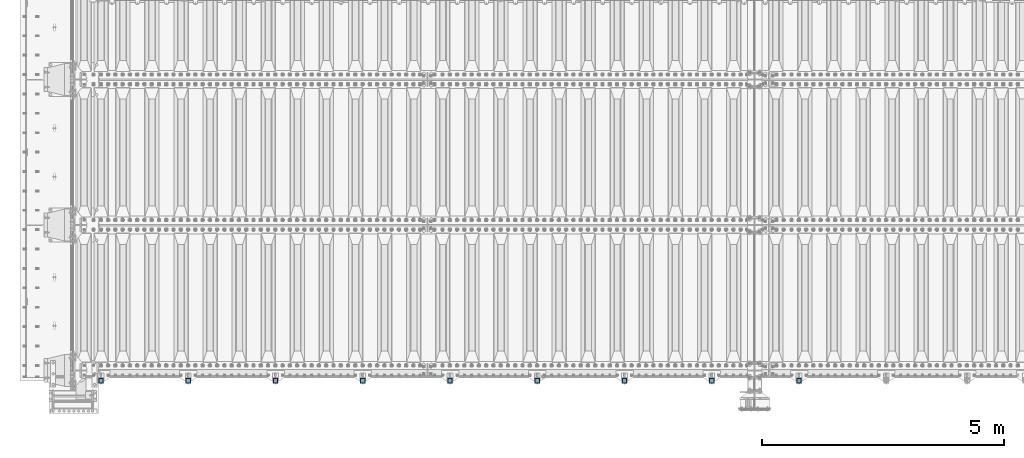
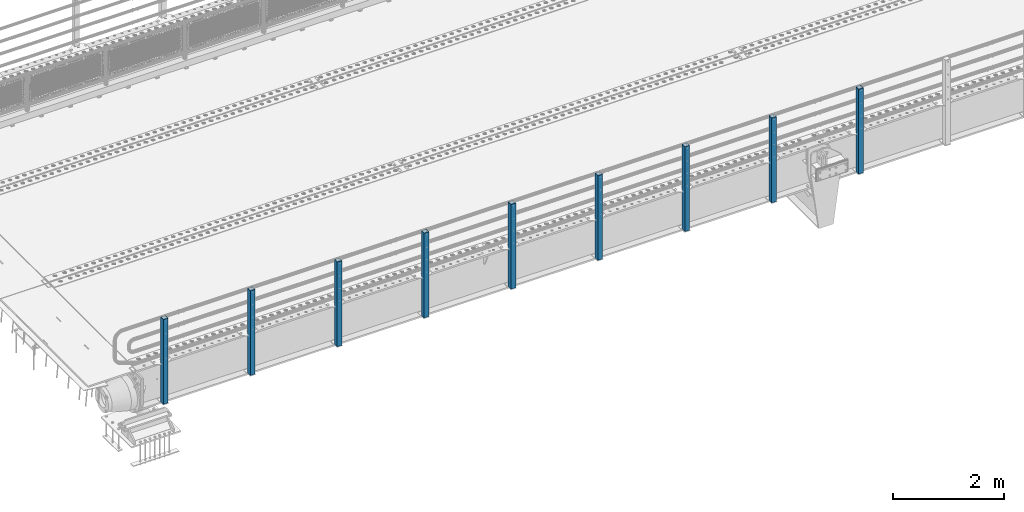
# One storey, part 61 of 270: 9 columns.
"""IFC2X3 building model written with IfcOpenShell, lengths in millimetres."""

from ifc_helpers import new_model, si_unit, frame, origin_with_axes, place, context, subcontext, project, spatial, faceted_brep, material, type_object, element, save


model = new_model("IFC2X3")

# Units and contexts
model_context = context("Model", 3, precision=1e-05, world=origin_with_axes())
body_context = subcontext(model_context, "Body", "Model", "MODEL_VIEW")
ifc_project = project(units=[si_unit("LENGTHUNIT", "METRE", prefix="MILLI"), si_unit("AREAUNIT", "SQUARE_METRE"), si_unit("VOLUMEUNIT", "CUBIC_METRE"), si_unit("MASSUNIT", "GRAM", prefix="KILO"), si_unit("TIMEUNIT", "SECOND"), si_unit("PLANEANGLEUNIT", "RADIAN"), si_unit("SOLIDANGLEUNIT", "STERADIAN"), si_unit("THERMODYNAMICTEMPERATUREUNIT", "DEGREE_CELSIUS"), si_unit("LUMINOUSINTENSITYUNIT", "LUMEN")], contexts=[model_context])

# Site, building, storey
site_placement = place(None, origin_with_axes())
site = spatial("IfcSite", under=ifc_project, at=site_placement, CompositionType="ELEMENT")
building_placement = place(site_placement, origin_with_axes())
building = spatial("IfcBuilding", under=site, at=building_placement, Name="Standard", CompositionType="ELEMENT")
storey_placement = place(building_placement, origin_with_axes())
storey = spatial("IfcBuildingStorey", under=building, at=storey_placement, Name="Undefined", CompositionType="ELEMENT", Elevation=0.0)

# Columns
ifc_material = material()
column_type = type_object("IfcColumnType", PredefinedType="NOTDEFINED")
for number, where, z_axis, x_axis in (
    (1, (14949.9999999999, -24210.0000000002, -844.999999999998), (0.0, 1.0, 0.0), (0.0, 0.0, 1.0)),
    (2, (13149.9999999999, -24210.0000000002, -844.999999999998), (0.0, 1.0, 0.0), (0.0, 0.0, 1.0)),
    (3, (11349.9999999999, -24210.0000000002, -844.999999999998), (0.0, 1.0, 0.0), (0.0, 0.0, 1.0)),
    (4, (9549.99999999987, -24210.0000000002, -844.999999999998), (0.0, 1.0, 0.0), (0.0, 0.0, 1.0)),
    (5, (7749.99999999987, -24210.0000000002, -844.999999999998), (0.0, 1.0, 0.0), (0.0, 0.0, 1.0)),
    (6, (5949.99999999987, -24210.0000000002, -844.999999999998), (0.0, 1.0, 0.0), (0.0, 0.0, 1.0)),
    (7, (4149.99999999987, -24210.0000000002, -844.999999999998), (0.0, 1.0, 0.0), (0.0, 0.0, 1.0)),
    (8, (2349.99999999987, -24210.0000000002, -844.999999999998), (0.0, 1.0, 0.0), (0.0, 0.0, 1.0)),
    (9, (549.999999999869, -24210.0000000002, -844.999999999998), (0.0, 1.0, 0.0), (0.0, 0.0, 1.0)),
):
    element("IfcColumn", number, at=place(storey_placement, frame(where, z_axis=z_axis, x_axis=x_axis)), inside=storey, type_object=column_type, material=ifc_material, context=body_context, shape_type="Brep", body=[
        faceted_brep([(0.0, 40.0, -40.0), (0.0, -40.0, -40.0), (1855.0, -40.0, -40.0), (1855.0, 40.0, -40.0), (0.0, -40.0, 40.0), (1855.0, -40.0, 40.0), (0.0, 40.0, 40.0), (1855.0, 40.0, 40.0), (0.0, 50.0, -50.0), (0.0, 50.0, 50.0), (1855.0, 50.0, 50.0), (1855.0, 50.0, -50.0), (0.0, -50.0, 50.0), (1855.0, -50.0, 50.0), (0.0, -50.0, -50.0), (1855.0, -50.0, -50.0)], [[[0, 1, 2, 3]], [[1, 4, 5, 2]], [[4, 6, 7, 5]], [[6, 0, 3, 7]], [[8, 9, 10, 11]], [[9, 12, 13, 10]], [[12, 14, 15, 13]], [[14, 8, 11, 15]], [[13, 15, 11, 10], [5, 7, 3, 2]], [[14, 12, 9, 8], [6, 4, 1, 0]]]),
    ])

save(model, "model.ifc")
